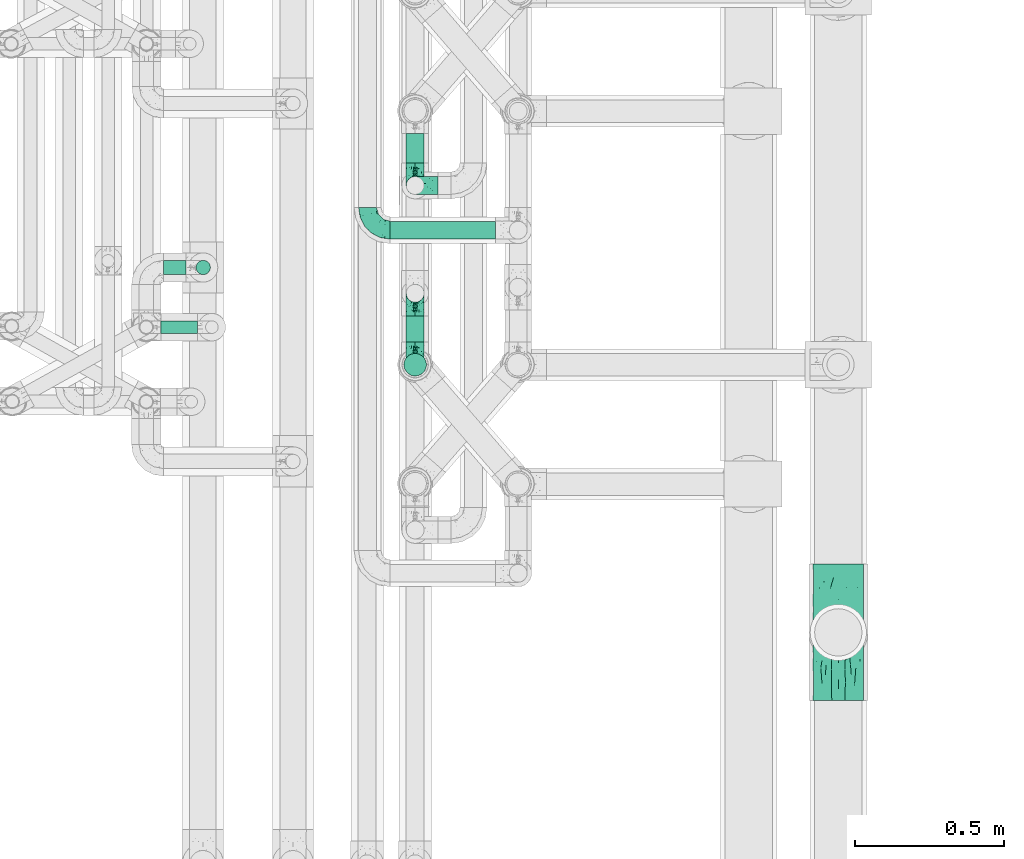
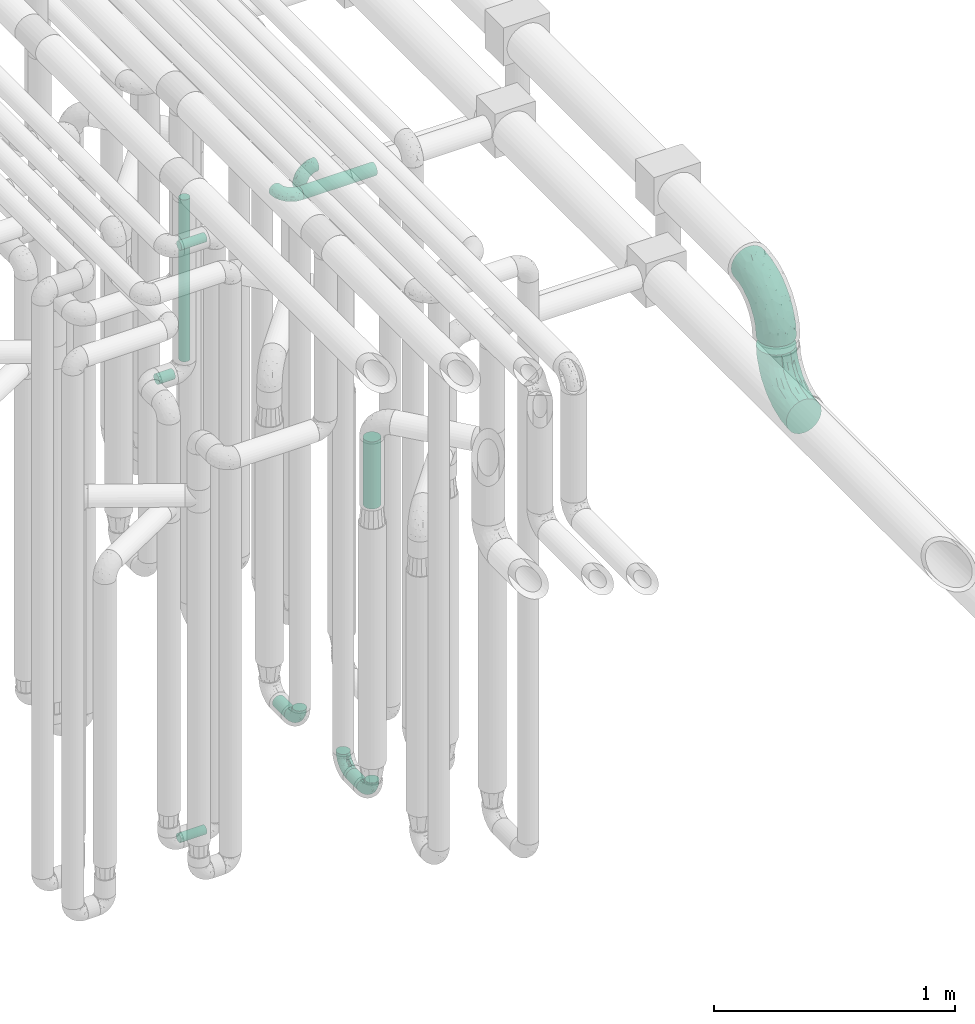
# One storey, part 610 of 827: 8 flow segments, 7 flow fittings.
"""IFC2X3 building model written with IfcOpenShell, lengths in millimetres."""

import ifcopenshell
import ifcopenshell.guid

model = None  # the IFC model being written
_history = None  # IfcOwnerHistory: only IFC2X3 demands one
_inside = {}  # id of a spatial element -> (the spatial element, [elements in it])
_under = {}  # id of a project, library or spatial element -> (it, [spatial elements below it])
_declared = {}  # id of a project -> (the project, [libraries it declares])
_typed = {}  # id of a type object -> (the type object, [elements of that type])
_made_of = {}  # id of a material, layer set ... -> (it, [elements and type objects made of it])


def new_model(schema):
    """Start an empty IFC model of exactly this schema.

    Asked for "IFC4X3", IfcOpenShell would pick the latest addendum, in which some entities
    have other attributes; the version numbers below select the first issue.
    IFC2X3 requires an IfcOwnerHistory on every rooted entity: one is made here for all.
    """
    global model, _history
    if schema == "IFC4X3":
        model = ifcopenshell.file(schema_version=(4, 3, 0, 0))
    else:
        model = ifcopenshell.file(schema=schema)
    _inside.clear()
    _under.clear()
    _declared.clear()
    _typed.clear()
    _made_of.clear()
    _history = None
    if model.schema == "IFC2X3":
        org = make("IfcOrganization", Name="unknown")
        user = make(
            "IfcPersonAndOrganization",
            ThePerson=make("IfcPerson", FamilyName="unknown"),
            TheOrganization=org,
        )
        app = make(
            "IfcApplication",
            ApplicationDeveloper=org,
            Version="unknown",
            ApplicationFullName="unknown",
            ApplicationIdentifier="unknown",
        )
        _history = make(
            "IfcOwnerHistory",
            OwningUser=user,
            OwningApplication=app,
            ChangeAction="ADDED",
            CreationDate=0,
        )
    return model


def make(cls, **values):
    """One entity of the class cls with the attributes given. An attribute that is None is left unset."""
    return model.create_entity(
        cls, **{name: value for name, value in values.items() if value is not None}
    )


def entity(cls, *values):
    """Any entity or typed value of the class cls, its attributes in the order of the schema. None: left unset."""
    e = model.create_entity(cls)
    for i, value in enumerate(values):
        if value is not None:
            e[i] = value
    return e


def rooted(cls, **values):
    """An entity with a GlobalId (a new one), such as an element, a storey or a relation."""
    return make(cls, GlobalId=ifcopenshell.guid.new(), OwnerHistory=_history, **values)


def si_unit(unit_type, name, prefix=None):
    """IfcSIUnit, for example si_unit("LENGTHUNIT", "METRE", prefix="MILLI")."""
    return make("IfcSIUnit", UnitType=unit_type, Prefix=prefix, Name=name)


def converted_unit(unit_type, name, factor, base, dimensions=None, offset=None):
    """IfcConversionBasedUnit, such as the inch: factor (a typed value) times the base unit."""
    return make(
        "IfcConversionBasedUnit"
        if offset is None
        else "IfcConversionBasedUnitWithOffset",
        ConversionOffset=offset,
        Dimensions=None
        if dimensions is None
        else entity("IfcDimensionalExponents", *dimensions),
        UnitType=unit_type,
        Name=name,
        ConversionFactor=make(
            "IfcMeasureWithUnit", ValueComponent=factor, UnitComponent=base
        ),
    )


def derived_unit(unit_type, elements):
    """IfcDerivedUnit: a product of units, each with its exponent."""
    return make(
        "IfcDerivedUnit",
        Elements=[
            make("IfcDerivedUnitElement", Unit=unit, Exponent=power)
            for unit, power in elements
        ],
        UnitType=unit_type,
    )


def assignment(units):
    """IfcUnitAssignment: the units of a project."""
    return None if units is None else make("IfcUnitAssignment", Units=units)


def point(xyz):
    """IfcCartesianPoint."""
    return None if xyz is None else make("IfcCartesianPoint", Coordinates=xyz)


def direction(xyz):
    """IfcDirection."""
    return None if xyz is None else make("IfcDirection", DirectionRatios=xyz)


def frame(location, z_axis=None, x_axis=None):
    """IfcAxis2Placement3D, a coordinate frame: its origin and axes. An axis left out is left unset."""
    return make(
        "IfcAxis2Placement3D",
        Location=point(location),
        Axis=direction(z_axis),
        RefDirection=direction(x_axis),
    )


def frame_2d(location, x_axis=None):
    """IfcAxis2Placement2D, a coordinate frame in the plane: its origin and x axis."""
    return make(
        "IfcAxis2Placement2D", Location=point(location), RefDirection=direction(x_axis)
    )


def origin():
    """The frame at (0, 0, 0) with its axes left unset."""
    return frame((0.0, 0.0, 0.0))


def origin_2d_with_axis():
    """The frame at (0, 0) in the plane with the x axis (1, 0) written out."""
    return frame_2d((0.0, 0.0), x_axis=(1.0, 0.0))


def place(relative_to, where):
    """IfcLocalPlacement: puts the frame where relative to a parent placement (None: the world)."""
    return make(
        "IfcLocalPlacement", PlacementRelTo=relative_to, RelativePlacement=where
    )


def context(
    kind, dimensions, precision=None, world=None, true_north=None, identifier=None
):
    """IfcGeometricRepresentationContext, for example the 3D "Model" context."""
    return make(
        "IfcGeometricRepresentationContext",
        ContextIdentifier=identifier,
        ContextType=kind,
        CoordinateSpaceDimension=dimensions,
        Precision=precision,
        WorldCoordinateSystem=world,
        TrueNorth=true_north,
    )


def subcontext(parent, identifier, kind, view, scale=None):
    """IfcGeometricRepresentationSubContext, for example "Body" below "Model"."""
    return make(
        "IfcGeometricRepresentationSubContext",
        ContextIdentifier=identifier,
        ContextType=kind,
        ParentContext=parent,
        TargetScale=scale,
        TargetView=view,
    )


def project(units=None, contexts=None):
    """IfcProject with its units and contexts."""
    return rooted(
        "IfcProject",
        Name="project",
        RepresentationContexts=contexts,
        UnitsInContext=assignment(units),
    )


def spatial(cls, under=None, at=None, **own):
    """A site, building, storey or space (cls), placed at a placement, below another one or the project."""
    s = rooted(cls, ObjectPlacement=at, **own)
    if under is not None:
        _under.setdefault(under.id(), (under, []))[1].append(s)
    return s


def profile(cls, at=None, kind="AREA", **sizes):
    """A parametric profile (cls). Its sizes go by their IFC names, for example OverallWidth=200.0."""
    return make(cls, ProfileType=kind, Position=at, **sizes)


def circle(**sizes):
    """IfcCircleProfileDef."""
    return profile("IfcCircleProfileDef", **sizes)


def extrude(swept, where, along, depth):
    """IfcExtrudedAreaSolid: the profile swept, set in the frame where, extruded along a direction by depth."""
    return make(
        "IfcExtrudedAreaSolid",
        SweptArea=swept,
        Position=where,
        ExtrudedDirection=direction(along),
        Depth=depth,
    )


def faces_of(points, faces, orient=None, outer=None):
    """IfcFace entities. A face is a list of loops; a loop is a list of indices into points, from 0.

    orient and outer hold one flag for each loop. By default every Orientation is true, the
    first loop of a face is its IfcFaceOuterBound and the others are IfcFaceBound.
    """
    made = []
    for i, loops in enumerate(faces):
        bounds = []
        for j, loop in enumerate(loops):
            is_outer = j == 0 if outer is None else outer[i][j]
            bounds.append(
                make(
                    "IfcFaceOuterBound" if is_outer else "IfcFaceBound",
                    Bound=make("IfcPolyLoop", Polygon=[points[k] for k in loop]),
                    Orientation=True if orient is None else orient[i][j],
                )
            )
        made.append(make("IfcFace", Bounds=bounds))
    return made


def faceted_brep(points, faces, orient=None, outer=None, voids=None):
    """IfcFacetedBrep: a solid bounded by flat faces; with voids (closed shells), ...WithVoids."""
    shared = [point(p) for p in points]
    hull = make("IfcClosedShell", CfsFaces=faces_of(shared, faces, orient, outer))
    if voids is None:
        return make("IfcFacetedBrep", Outer=hull)
    return make(
        "IfcFacetedBrepWithVoids",
        Outer=hull,
        Voids=[
            make(cls, CfsFaces=faces_of(shared, fs, o, b)) for cls, fs, o, b in voids
        ],
    )


def shape(context_of_items, identifier, shape_type, items):
    """IfcShapeRepresentation: the items that make up one representation, for example the "Body"."""
    return make(
        "IfcShapeRepresentation",
        ContextOfItems=context_of_items,
        RepresentationIdentifier=identifier,
        RepresentationType=shape_type,
        Items=items,
    )


def source(mapping_origin, context_of_items, identifier, shape_type, items):
    """IfcRepresentationMap: a shape defined once, which mapped items show again and again."""
    return make(
        "IfcRepresentationMap",
        MappingOrigin=mapping_origin,
        MappedRepresentation=shape(context_of_items, identifier, shape_type, items),
    )


def transform(
    local_origin,
    x_axis=None,
    y_axis=None,
    z_axis=None,
    scale=None,
    scale2=None,
    scale3=None,
    uniform=True,
):
    """IfcCartesianTransformationOperator3D, or its non-uniform kind. x_axis, y_axis, z_axis: its Axis1, 2, 3."""
    if uniform:
        return make(
            "IfcCartesianTransformationOperator3D",
            Axis1=direction(x_axis),
            Axis2=direction(y_axis),
            LocalOrigin=point(local_origin),
            Scale=scale,
            Axis3=direction(z_axis),
        )
    return make(
        "IfcCartesianTransformationOperator3DnonUniform",
        Axis1=direction(x_axis),
        Axis2=direction(y_axis),
        LocalOrigin=point(local_origin),
        Scale=scale,
        Axis3=direction(z_axis),
        Scale2=scale2,
        Scale3=scale3,
    )


def mapped(mapping_source, mapping_target):
    """IfcMappedItem: shows the shape of a source again, moved by a transform."""
    return make(
        "IfcMappedItem", MappingSource=mapping_source, MappingTarget=mapping_target
    )


def material(Name=None, Category=None):
    """IfcMaterial."""
    return make("IfcMaterial", Name=Name, Category=Category)


def made_of(thing, what):
    """Note that an element or type object is made of a material, layer set ...; save() writes the relation."""
    if what is not None:
        _made_of.setdefault(what.id(), (what, []))[1].append(thing)
    return thing


def type_object(cls, material=None, **own):
    """A type object (cls), such as IfcWallType, which elements share."""
    return made_of(rooted(cls, **own), material)


def type_shapes(of_type, sources):
    """Give a type object the sources (RepresentationMaps) that its elements show as mapped items."""
    of_type.RepresentationMaps = sources


def element(
    cls,
    number,
    at=None,
    inside=None,
    cuts=None,
    type_object=None,
    material=None,
    context=None,
    identifier="Body",
    shape_type=None,
    held_by="IfcProductDefinitionShape",
    body=None,
    shapes=None,
    **own,
):
    """One element of the class cls, such as IfcWall. Its Tag is "e" and its number.

    at: its placement. inside: the storey or other place that contains it. cuts: it is an
    opening in that element (IfcRelVoidsElement). A single representation is given by context,
    identifier, shape_type and body (its items); several are given by shapes. held_by: the class
    of the entity that holds the representations. save() writes the other relations.
    """
    e = rooted(cls, Tag="e%d" % number, ObjectPlacement=at, **own)
    if body is not None:
        shapes = [shape(context, identifier, shape_type, body)]
    if shapes is not None:
        e.Representation = make(held_by, Representations=shapes)
    if inside is not None:
        _inside.setdefault(inside.id(), (inside, []))[1].append(e)
    if cuts is not None:
        rooted(
            "IfcRelVoidsElement", RelatingBuildingElement=cuts, RelatedOpeningElement=e
        )
    if type_object is not None:
        _typed.setdefault(type_object.id(), (type_object, []))[1].append(e)
    return made_of(e, material)


def aggregate(whole, parts):
    """IfcRelAggregates: a whole, such as a stair, and the parts it consists of."""
    return rooted("IfcRelAggregates", RelatingObject=whole, RelatedObjects=parts)


def save(model, path):
    """Write the relations noted so far, then the file.

    IfcRelAggregates (storeys below a building ...), IfcRelContainedInSpatialStructure (elements
    in a storey), IfcRelDefinesByType, IfcRelAssociatesMaterial and IfcRelDeclares: one each for
    every whole, place, type object, material and project.
    """
    for whole, parts in _under.values():
        aggregate(whole, parts)
    for where, things in _inside.values():
        rooted(
            "IfcRelContainedInSpatialStructure",
            RelatedElements=things,
            RelatingStructure=where,
        )
    for kind, things in _typed.values():
        rooted("IfcRelDefinesByType", RelatedObjects=things, RelatingType=kind)
    for what, things in _made_of.values():
        rooted("IfcRelAssociatesMaterial", RelatedObjects=things, RelatingMaterial=what)
    for by, libraries in _declared.values():
        rooted("IfcRelDeclares", RelatingContext=by, RelatedDefinitions=libraries)
    model.write(path)


model = new_model("IFC2X3")

# Units and contexts
model_context = context("Model", 3, precision=0.01, world=origin(), true_north=direction((6.12303176911189e-17, 1.0)))
body_context = subcontext(model_context, "Body", "Model", "MODEL_VIEW")
ifc_project = project(units=[si_unit("LENGTHUNIT", "METRE", prefix="MILLI"), si_unit("AREAUNIT", "SQUARE_METRE"), si_unit("VOLUMEUNIT", "CUBIC_METRE"), converted_unit("PLANEANGLEUNIT", "DEGREE", entity("IfcRatioMeasure", 0.0174532925199433), si_unit("PLANEANGLEUNIT", "RADIAN"), dimensions=[0, 0, 0, 0, 0, 0, 0]), si_unit("MASSUNIT", "GRAM", prefix="KILO"), derived_unit("MASSDENSITYUNIT", [(si_unit("MASSUNIT", "GRAM", prefix="KILO"), 1), (si_unit("LENGTHUNIT", "METRE"), -3)]), derived_unit("MOMENTOFINERTIAUNIT", [(si_unit("LENGTHUNIT", "METRE"), 4)]), si_unit("TIMEUNIT", "SECOND"), si_unit("FREQUENCYUNIT", "HERTZ"), si_unit("THERMODYNAMICTEMPERATUREUNIT", "DEGREE_CELSIUS"), derived_unit("THERMALTRANSMITTANCEUNIT", [(si_unit("MASSUNIT", "GRAM", prefix="KILO"), 1), (si_unit("THERMODYNAMICTEMPERATUREUNIT", "KELVIN"), -1), (si_unit("TIMEUNIT", "SECOND"), -3)]), derived_unit("VOLUMETRICFLOWRATEUNIT", [(si_unit("LENGTHUNIT", "METRE"), 3), (si_unit("TIMEUNIT", "SECOND"), -1)]), derived_unit("MASSFLOWRATEUNIT", [(si_unit("MASSUNIT", "GRAM", prefix="KILO"), 1), (si_unit("TIMEUNIT", "SECOND"), -1)]), derived_unit("ROTATIONALFREQUENCYUNIT", [(si_unit("TIMEUNIT", "SECOND"), -1)]), si_unit("ELECTRICCURRENTUNIT", "AMPERE"), si_unit("ELECTRICVOLTAGEUNIT", "VOLT"), si_unit("POWERUNIT", "WATT"), si_unit("FORCEUNIT", "NEWTON", prefix="KILO"), si_unit("ILLUMINANCEUNIT", "LUX"), si_unit("LUMINOUSFLUXUNIT", "LUMEN"), si_unit("LUMINOUSINTENSITYUNIT", "CANDELA"), derived_unit("USERDEFINED", [(si_unit("MASSUNIT", "GRAM", prefix="KILO"), -1), (si_unit("LENGTHUNIT", "METRE"), -2), (si_unit("TIMEUNIT", "SECOND"), 3), (si_unit("LUMINOUSFLUXUNIT", "LUMEN"), 1)]), derived_unit("LINEARVELOCITYUNIT", [(si_unit("LENGTHUNIT", "METRE"), 1), (si_unit("TIMEUNIT", "SECOND"), -1)]), si_unit("PRESSUREUNIT", "PASCAL"), derived_unit("USERDEFINED", [(si_unit("LENGTHUNIT", "METRE"), -2), (si_unit("MASSUNIT", "GRAM", prefix="KILO"), 1), (si_unit("TIMEUNIT", "SECOND"), -2)]), derived_unit("LINEARFORCEUNIT", [(si_unit("MASSUNIT", "GRAM", prefix="KILO"), 1), (si_unit("LENGTHUNIT", "METRE"), 1), (si_unit("TIMEUNIT", "SECOND"), -2), (si_unit("LENGTHUNIT", "METRE"), -1)]), derived_unit("PLANARFORCEUNIT", [(si_unit("MASSUNIT", "GRAM", prefix="KILO"), 1), (si_unit("LENGTHUNIT", "METRE"), 1), (si_unit("TIMEUNIT", "SECOND"), -2), (si_unit("LENGTHUNIT", "METRE"), -2)])], contexts=[model_context])

# Site, building, storey
site_placement = place(None, origin())
site = spatial("IfcSite", under=ifc_project, at=site_placement, CompositionType="ELEMENT")
building_placement = place(site_placement, origin())
building = spatial("IfcBuilding", under=site, at=building_placement, CompositionType="ELEMENT")
storey_placement = place(building_placement, frame((0.0, 0.0, 28200.0)))
storey = spatial("IfcBuildingStorey", under=building, at=storey_placement, Name="08", CompositionType="ELEMENT", Elevation=28200.0)

# Flow segments
pipe_segment_type = type_object("IfcPipeSegmentType", PredefinedType="NOTDEFINED")
flow_segment_1_placement = place(storey_placement, frame((36598.05, 11157.17, 368.4)))
element("IfcFlowSegment", 1, at=flow_segment_1_placement, inside=storey, type_object=pipe_segment_type, context=body_context, shape_type="SweptSolid", body=[
    extrude(circle(Radius=30.0, at=origin_2d_with_axis()), frame((31.6, 0.0, 31.6), z_axis=(0.0, 1.0, 0.0), x_axis=(1.0, 0.0, 0.0)), (0.0, 0.0, 1.0), 98.4177180789936),
])
flow_segment_2_placement = place(storey_placement, frame((36546.03, 10899.58, 3168.4)))
element("IfcFlowSegment", 2, at=flow_segment_2_placement, inside=storey, type_object=pipe_segment_type, context=body_context, shape_type="SweptSolid", body=[
    extrude(circle(Radius=30.0, at=origin_2d_with_axis()), frame((0.0, 31.6, 31.6), z_axis=(1.0, 0.0, 0.0), x_axis=(0.0, 1.0, 0.0)), (0.0, 0.0, 1.0), 352.999982000065),
])
flow_segment_3_placement = place(storey_placement, frame((36598.05, 10556.2, 368.4)))
element("IfcFlowSegment", 3, at=flow_segment_3_placement, inside=storey, type_object=pipe_segment_type, context=body_context, shape_type="SweptSolid", body=[
    extrude(circle(Radius=30.0, at=origin_2d_with_axis()), frame((31.6, 0.0, 31.6), z_axis=(0.0, 1.0, 0.0), x_axis=(-1.0, 0.0, 0.0)), (0.0, 0.0, 1.0), 87.5194852591066),
])
flow_segment_4_placement = place(storey_placement, frame((36590.3, 10440.86, 1870.0)))
element("IfcFlowSegment", 4, at=flow_segment_4_placement, inside=storey, type_object=pipe_segment_type, context=body_context, shape_type="SweptSolid", body=[
    extrude(circle(Radius=37.75, at=origin_2d_with_axis()), frame((39.35, 39.35, 0.0)), (0.0, 0.0, 1.0), 340.000000000014),
])
flow_segment_5_placement = place(storey_placement, frame((35776.05, 10583.46, 377.25)))
element("IfcFlowSegment", 5, at=flow_segment_5_placement, inside=storey, type_object=pipe_segment_type, context=body_context, shape_type="SweptSolid", body=[
    extrude(circle(Radius=21.15, at=origin_2d_with_axis()), frame((0.0, 22.75, 22.75), z_axis=(1.0, 0.0, 0.0), x_axis=(0.0, 1.0, 0.0)), (0.0, 0.0, 1.0), 124.000000000006),
])
flow_segment_6_placement = place(storey_placement, frame((35785.05, 10780.61, 2574.4)))
element("IfcFlowSegment", 6, at=flow_segment_6_placement, inside=storey, type_object=pipe_segment_type, context=body_context, shape_type="SweptSolid", body=[
    extrude(circle(Radius=24.0, at=origin_2d_with_axis()), frame((0.0, 25.6, 25.6), z_axis=(1.0, -8.65020701261313e-08, 0.0), x_axis=(-8.65020701261313e-08, -1.0, 0.0)), (0.0, 0.0, 1.0), 76.9274934935988),
])
flow_segment_7_placement = place(storey_placement, frame((35893.38, 10780.61, 2657.0)))
element("IfcFlowSegment", 7, at=flow_segment_7_placement, inside=storey, type_object=pipe_segment_type, context=body_context, shape_type="SweptSolid", body=[
    extrude(circle(Radius=24.0, at=origin_2d_with_axis()), frame((25.6, 25.6, 0.0)), (0.0, 0.0, 1.0), 820.000867851719),
])
flow_segment_8_placement = place(storey_placement, frame((35778.03, 10583.46, 3377.25)))
element("IfcFlowSegment", 8, at=flow_segment_8_placement, inside=storey, type_object=pipe_segment_type, context=body_context, shape_type="SweptSolid", body=[
    extrude(circle(Radius=21.15, at=origin_2d_with_axis()), frame((0.0, 22.75, 22.75), z_axis=(1.0, 0.0, 0.0), x_axis=(0.0, 1.0, 0.0)), (0.0, 0.0, 1.0), 122.01386037804),
])

# Flow fittings
ifc_material = material()
pipe_fitting_type_1 = type_object("IfcPipeFittingType", Name="ADSK_1", PredefinedType="NOTDEFINED", material=ifc_material)
shared_shape_1 = source(origin(), body_context, "Body", "Brep", [
    faceted_brep([(-76.0, 15.07, -26.11), (-76.0, 7.8, -29.12), (-76.0, 0.0, -30.15), (-76.0, -7.8, -29.12), (-76.0, -15.08, -26.11), (-76.0, -21.32, -21.32), (-76.0, -26.11, -15.08), (-76.0, -29.12, -7.8), (-76.0, -30.15, 0.0), (-76.0, -29.12, 7.8), (-76.0, -26.11, 15.07), (-76.0, -21.32, 21.32), (-76.0, -15.08, 26.11), (-76.0, -7.8, 29.12), (-76.0, 0.0, 30.15), (-76.0, 7.8, 29.12), (-76.0, 15.07, 26.11), (-76.0, 21.32, 21.32), (-76.0, 26.11, 15.07), (-76.0, 29.12, 7.8), (-76.0, 30.15, 0.0), (-76.0, 29.12, -7.8), (-76.0, 26.11, -15.08), (-76.0, 21.32, -21.32), (0.0, 76.0, -30.15), (-7.8, 76.0, -29.12), (-15.07, 76.0, -26.11), (-21.32, 76.0, -21.32), (-26.11, 76.0, -15.08), (-29.12, 76.0, -7.8), (-30.15, 76.0, 0.0), (-29.12, 76.0, 7.8), (-26.11, 76.0, 15.07), (-21.32, 76.0, 21.32), (-15.07, 76.0, 26.11), (-7.8, 76.0, 29.12), (0.0, 76.0, 30.15), (7.8, 76.0, 29.12), (15.08, 76.0, 26.11), (21.32, 76.0, 21.32), (26.11, 76.0, 15.07), (29.12, 76.0, 7.8), (30.15, 76.0, 0.0), (29.12, 76.0, -7.8), (26.11, 76.0, -15.08), (21.32, 76.0, -21.32), (15.08, 76.0, -26.11), (7.8, 76.0, -29.12), (10.79, 31.43, 21.07), (4.32, 31.7, 25.72), (1.65, 15.19, 19.92), (-61.17, -27.8, 0.0), (-51.1, -25.49, 9.84), (-56.14, -10.61, 27.27), (-31.7, -4.32, 25.72), (-39.75, 1.72, 29.41), (-43.2, -24.95, 0.0), (-1.86, 1.86, 0.0), (4.49, 7.65, 5.78), (-7.82, -4.61, 5.83), (-56.21, -22.79, 17.21), (-58.98, -3.38, 29.7), (-53.96, 5.6, 30.07), (-10.86, 10.86, 25.48), (-17.2, -2.6, 20.44), (-49.15, -16.01, 22.7), (-22.18, -14.24, 7.99), (-28.4, -17.42, 0.0), (-13.61, -9.88, 0.0), (-39.0, 23.48, 27.76), (-58.76, 12.54, 28.36), (-41.61, 15.41, 29.48), (16.01, 49.15, 22.7), (-58.55, 25.93, 19.53), (-51.53, 33.5, 13.51), (-64.92, 28.76, 12.4), (-7.48, 23.14, 28.25), (-1.72, 39.75, 29.41), (-12.04, 27.88, 29.88), (-63.91, 18.81, 24.52), (-11.63, 65.16, 28.18), (-4.97, 57.02, 30.05), (9.88, 13.61, 0.0), (-62.5, 31.74, 5.02), (-45.17, 30.98, 21.2), (-21.78, 9.76, 28.58), (10.61, 56.14, 27.27), (-32.09, 54.42, 13.26), (22.79, 56.21, 17.21), (15.38, 31.17, 15.63), (25.49, 51.1, 9.84), (21.84, 36.35, 5.92), (24.95, 43.2, 0.0), (3.38, 58.98, 29.7), (-31.17, -15.38, 15.63), (-39.39, 41.78, 15.45), (-34.56, 41.13, 20.79), (-39.81, -23.25, 5.49), (27.8, 61.17, 0.0), (-31.74, 62.5, 5.02), (-53.07, 36.29, 0.0), (-42.95, 42.95, 7.29), (-36.29, 53.07, 0.0), (-19.83, 58.51, 24.79), (-25.48, 60.2, 19.41), (-14.53, 50.96, 28.57), (-13.31, 37.09, 30.07), (-26.16, 40.06, 26.4), (-32.43, -10.35, 21.9), (17.42, 28.4, 0.0), (14.24, 22.18, 7.99), (-38.67, 9.72, 30.15), (-24.66, 17.36, 30.09), (-37.08, 31.49, 24.99), (-49.27, 22.83, 25.24), (-20.8, 38.81, 28.63), (-27.58, 27.58, 29.2), (-36.07, -20.23, 10.71), (-15.19, -6.16, 14.9), (6.6, 15.4, 14.49), (-2.51, 2.51, 11.35), (-65.16, 11.63, -28.18), (-49.15, -16.01, -22.7), (-57.02, 4.97, -30.05), (-25.93, 58.55, -19.53), (-33.5, 51.53, -13.51), (-28.76, 64.92, -12.4), (-60.2, 25.48, -19.41), (-58.51, 19.83, -24.79), (4.61, 7.82, -5.83), (-7.65, -4.49, -5.78), (-2.51, 2.51, -11.35), (-62.5, 31.74, -5.02), (-50.96, 14.53, -28.57), (-37.09, 13.31, -30.07), (-42.95, 42.95, -7.29), (25.49, 51.1, -9.84), (22.79, 56.21, -17.21), (-40.06, 26.16, -26.4), (3.38, 58.98, -29.7), (-5.6, 53.96, -30.07), (-27.88, 12.04, -29.88), (-9.76, 21.78, -28.58), (-23.14, 7.48, -28.25), (-51.1, -25.49, -9.84), (15.38, 31.17, -15.63), (16.01, 49.15, -22.7), (-23.48, 39.0, -27.76), (-12.54, 58.76, -28.36), (-15.41, 41.61, -29.48), (-56.21, -22.79, -17.21), (-9.72, 38.67, -30.15), (-17.36, 24.66, -30.09), (-22.18, -14.24, -7.99), (-41.13, 34.56, -20.79), (-31.74, 62.5, -5.02), (-58.98, -3.38, -29.7), (-31.17, -15.38, -15.63), (-56.14, -10.61, -27.27), (14.24, 22.18, -7.99), (23.25, 39.81, -5.49), (-31.49, 37.08, -24.99), (-15.19, -6.16, -14.9), (1.65, 15.19, -19.92), (-18.81, 63.91, -24.52), (-32.59, -11.62, -20.84), (-31.7, -4.32, -25.72), (-17.2, -2.6, -20.44), (-39.75, 1.72, -29.41), (-54.42, 32.09, -13.26), (-30.98, 45.17, -21.2), (10.61, 56.14, -27.27), (10.23, 31.31, -21.52), (4.32, 31.7, -25.72), (-41.78, 39.39, -15.45), (-1.72, 39.75, -29.41), (-36.35, -21.84, -5.92), (-22.83, 49.27, -25.24), (-38.81, 20.8, -28.63), (-27.58, 27.58, -29.2), (-10.86, 10.86, -25.48), (20.23, 36.07, -10.71), (6.6, 15.4, -14.49)], [[[0, 1, 2, 3, 4, 5, 6, 7, 8, 9, 10, 11, 12, 13, 14, 15, 16, 17, 18, 19, 20, 21, 22, 23]], [[24, 25, 26, 27, 28, 29, 30, 31, 32, 33, 34, 35, 36, 37, 38, 39, 40, 41, 42, 43, 44, 45, 46, 47]], [[48, 49, 50]], [[51, 52, 9]], [[53, 54, 55]], [[9, 52, 10]], [[56, 52, 51]], [[57, 58, 59]], [[11, 10, 60]], [[14, 61, 62]], [[63, 54, 64]], [[65, 12, 11]], [[65, 53, 12]], [[66, 67, 68]], [[69, 70, 71]], [[72, 39, 38]], [[73, 74, 75]], [[15, 70, 16]], [[76, 77, 78]], [[16, 79, 17]], [[13, 61, 14]], [[35, 80, 81]], [[14, 62, 15]], [[17, 73, 18]], [[57, 82, 58]], [[20, 19, 83]], [[75, 19, 18]], [[70, 15, 62]], [[73, 84, 74]], [[78, 85, 76]], [[38, 86, 72]], [[32, 31, 87]], [[88, 89, 90]], [[91, 92, 90]], [[72, 86, 49]], [[36, 93, 37]], [[75, 83, 19]], [[36, 35, 81]], [[60, 94, 65]], [[40, 90, 41]], [[95, 96, 87]], [[88, 90, 40]], [[66, 97, 67]], [[90, 98, 41]], [[40, 39, 88]], [[99, 31, 30]], [[20, 83, 100]], [[101, 102, 100]], [[52, 60, 10]], [[102, 99, 30]], [[96, 103, 104]], [[83, 101, 100]], [[12, 53, 13]], [[104, 103, 33]], [[105, 106, 81]], [[107, 105, 103]], [[64, 54, 108]], [[80, 103, 105]], [[80, 35, 34]], [[34, 33, 103]], [[86, 38, 37]], [[109, 110, 82]], [[71, 111, 112]], [[69, 107, 113]], [[79, 73, 17]], [[114, 113, 84]], [[33, 32, 104]], [[115, 107, 116]], [[105, 115, 106]], [[93, 81, 77]], [[54, 53, 65]], [[61, 53, 55]], [[108, 94, 64]], [[54, 63, 85]], [[93, 86, 37]], [[77, 76, 49]], [[77, 49, 86]], [[49, 63, 50]], [[60, 52, 117]], [[65, 11, 60]], [[39, 72, 88]], [[89, 88, 72]], [[71, 70, 62]], [[79, 70, 114]], [[103, 96, 107]], [[69, 113, 114]], [[112, 106, 116]], [[77, 81, 106]], [[112, 116, 71]], [[112, 55, 85]], [[64, 50, 63]], [[57, 59, 68]], [[32, 87, 104]], [[96, 104, 87]], [[94, 118, 64]], [[50, 119, 89]], [[50, 64, 118]], [[50, 89, 48]], [[81, 93, 36]], [[86, 93, 77]], [[53, 61, 13]], [[62, 61, 55]], [[71, 62, 111]], [[69, 71, 116]], [[95, 101, 74]], [[99, 101, 87]], [[118, 66, 59]], [[117, 97, 66]], [[117, 66, 94]], [[91, 89, 110]], [[91, 110, 109]], [[110, 89, 119]], [[9, 8, 51]], [[98, 90, 92]], [[98, 42, 41]], [[101, 83, 74]], [[101, 99, 102]], [[87, 31, 99]], [[62, 55, 111]], [[55, 112, 111]], [[107, 69, 116]], [[70, 69, 114]], [[107, 96, 113]], [[84, 113, 96]], [[84, 96, 95]], [[114, 84, 73]], [[70, 79, 16]], [[73, 79, 114]], [[54, 85, 55]], [[76, 85, 63]], [[49, 76, 63]], [[77, 106, 78]], [[106, 112, 78]], [[85, 78, 112]], [[73, 75, 18]], [[83, 75, 74]], [[103, 80, 34]], [[81, 80, 105]], [[101, 95, 87]], [[84, 95, 74]], [[106, 115, 116]], [[105, 107, 115]], [[120, 59, 58]], [[82, 110, 58]], [[119, 58, 110]], [[118, 59, 120]], [[66, 68, 59]], [[54, 65, 108]], [[94, 108, 65]], [[66, 118, 94]], [[50, 118, 120]], [[50, 120, 119]], [[119, 120, 58]], [[89, 72, 48]], [[49, 48, 72]], [[60, 117, 94]], [[117, 52, 97]], [[52, 56, 97]], [[67, 97, 56]], [[92, 91, 109]], [[89, 91, 90]], [[121, 1, 0]], [[122, 5, 4]], [[2, 1, 123]], [[124, 125, 126]], [[127, 128, 23]], [[129, 130, 131]], [[100, 132, 20]], [[133, 134, 123]], [[135, 100, 102]], [[136, 137, 44]], [[133, 128, 138]], [[24, 139, 140]], [[141, 142, 143]], [[121, 128, 133]], [[6, 144, 7]], [[137, 145, 146]], [[144, 51, 7]], [[147, 148, 149]], [[144, 6, 150]], [[149, 151, 152]], [[153, 68, 67]], [[154, 128, 127]], [[30, 155, 102]], [[43, 42, 98]], [[156, 3, 2]], [[157, 144, 150]], [[158, 4, 3]], [[24, 140, 25]], [[155, 135, 102]], [[159, 160, 109]], [[30, 29, 155]], [[147, 138, 161]], [[27, 124, 28]], [[57, 129, 82]], [[162, 163, 131]], [[27, 26, 164]], [[148, 26, 25]], [[165, 166, 167]], [[24, 47, 139]], [[143, 168, 141]], [[22, 21, 169]], [[125, 124, 170]], [[148, 25, 140]], [[46, 146, 171]], [[158, 122, 4]], [[0, 23, 128]], [[1, 121, 123]], [[109, 82, 159]], [[45, 44, 137]], [[146, 46, 45]], [[136, 43, 98]], [[132, 21, 20]], [[136, 98, 92]], [[172, 173, 146]], [[46, 171, 47]], [[43, 136, 44]], [[174, 154, 169]], [[171, 173, 175]], [[6, 5, 150]], [[126, 29, 28]], [[176, 56, 144]], [[122, 158, 166]], [[164, 124, 27]], [[177, 161, 170]], [[23, 22, 127]], [[178, 138, 179]], [[133, 178, 134]], [[156, 123, 168]], [[156, 158, 3]], [[168, 143, 166]], [[168, 166, 158]], [[166, 180, 167]], [[173, 171, 146]], [[139, 171, 175]], [[172, 145, 163]], [[173, 180, 142]], [[5, 122, 150]], [[157, 150, 122]], [[137, 136, 181]], [[146, 45, 137]], [[149, 148, 140]], [[164, 148, 177]], [[128, 154, 138]], [[147, 161, 177]], [[152, 134, 179]], [[168, 123, 134]], [[152, 179, 149]], [[152, 175, 142]], [[57, 130, 129]], [[157, 165, 167]], [[22, 169, 127]], [[154, 127, 169]], [[163, 167, 180]], [[162, 157, 167]], [[173, 163, 180]], [[182, 163, 145]], [[123, 156, 2]], [[158, 156, 168]], [[171, 139, 47]], [[140, 139, 175]], [[149, 140, 151]], [[147, 149, 179]], [[174, 135, 125]], [[132, 135, 169]], [[176, 157, 153]], [[176, 153, 67]], [[153, 157, 162]], [[182, 159, 129]], [[181, 160, 159]], [[181, 159, 145]], [[51, 144, 56]], [[51, 8, 7]], [[135, 132, 100]], [[169, 21, 132]], [[126, 155, 29]], [[135, 155, 125]], [[140, 175, 151]], [[175, 152, 151]], [[138, 147, 179]], [[148, 147, 177]], [[138, 154, 161]], [[170, 161, 154]], [[170, 154, 174]], [[177, 170, 124]], [[148, 164, 26]], [[124, 164, 177]], [[173, 142, 175]], [[143, 142, 180]], [[166, 143, 180]], [[168, 134, 141]], [[134, 152, 141]], [[142, 141, 152]], [[124, 126, 28]], [[155, 126, 125]], [[128, 121, 0]], [[123, 121, 133]], [[135, 174, 169]], [[170, 174, 125]], [[134, 178, 179]], [[133, 138, 178]], [[130, 153, 162]], [[68, 153, 130]], [[57, 68, 130]], [[182, 129, 131]], [[159, 82, 129]], [[157, 122, 165]], [[166, 165, 122]], [[163, 162, 167]], [[162, 131, 130]], [[145, 172, 146]], [[163, 173, 172]], [[159, 182, 145]], [[131, 163, 182]], [[56, 176, 67]], [[157, 176, 144]], [[137, 181, 145]], [[181, 136, 160]], [[136, 92, 160]], [[109, 160, 92]]]),
])
type_shapes(pipe_fitting_type_1, [shared_shape_1])
for number, where, z_axis, x_axis, name in (
    (9, (36629.64, 11081.17, 400.0), (-1.0, 0.0, 0.0), (0.0, -1.0, 0.0), "ADSK_1"),
    (10, (36629.64, 11081.17, 3200.0), (0.0, 1.0, 0.0), (0.0, 0.0, 1.0), "ADSK_1"),
    (11, (36470.03, 10931.17, 3200.0), (0.0, 0.0, 1.0), (0.0, -1.0, 0.0), "ADSK_1"),
    (12, (36629.64, 10480.2, 400.0), (-1.0, 0.0, 0.0), (0.0, -1.0, 0.0), "ADSK_1"),
    (13, (36629.64, 10719.72, 400.0), (1.0, 0.0, 0.0), (0.0, 1.0, 0.0), "ADSK_1"),
):
    element("IfcFlowFitting", number, at=place(storey_placement, frame(where, z_axis=z_axis, x_axis=x_axis)), inside=storey, type_object=pipe_fitting_type_1, material=ifc_material, Name=name, ObjectType="ADSK_1", context=body_context, shape_type="MappedRepresentation", body=[
        mapped(shared_shape_1, transform((0.0, 0.0, 0.0), scale=1.0)),
    ])
pipe_fitting_type_2 = type_object("IfcPipeFittingType", Name="ADSK_1", PredefinedType="NOTDEFINED", material=ifc_material)
shared_shape_2 = source(origin(), body_context, "Body", "Brep", [
    faceted_brep([(-229.0, 0.0, -84.15), (-229.0, -21.78, -81.28), (-229.0, -42.08, -72.88), (-229.0, -59.5, -59.5), (-229.0, -72.88, -42.08), (-229.0, -81.28, -21.78), (-229.0, -84.15, 0.0), (-229.0, -81.28, 21.78), (-229.0, -72.88, 42.07), (-229.0, -59.5, 59.5), (-229.0, -42.08, 72.88), (-229.0, -21.78, 81.28), (-229.0, 0.0, 84.15), (-229.0, 21.78, 81.28), (-229.0, 42.07, 72.88), (-229.0, 59.5, 59.5), (-229.0, 72.88, 42.07), (-229.0, 81.28, 21.78), (-229.0, 84.15, 0.0), (-229.0, 81.28, -21.78), (-229.0, 72.88, -42.08), (-229.0, 59.5, -59.5), (-229.0, 42.07, -72.88), (-229.0, 21.78, -81.28), (-21.78, 229.0, -81.28), (-42.07, 229.0, -72.88), (-59.5, 229.0, -59.5), (-72.88, 229.0, -42.08), (-81.28, 229.0, -21.78), (-84.15, 229.0, 0.0), (-81.28, 229.0, 21.78), (-72.88, 229.0, 42.07), (-59.5, 229.0, 59.5), (-42.07, 229.0, 72.88), (-21.78, 229.0, 81.28), (0.0, 229.0, 84.15), (21.78, 229.0, 81.28), (42.08, 229.0, 72.88), (59.5, 229.0, 59.5), (72.88, 229.0, 42.07), (81.28, 229.0, 21.78), (84.15, 229.0, 0.0), (81.28, 229.0, -21.78), (72.88, 229.0, -42.08), (59.5, 229.0, -59.5), (42.08, 229.0, -72.88), (21.78, 229.0, -81.28), (0.0, 229.0, -84.15), (-34.61, -10.71, 27.22), (-55.02, -31.37, 0.0), (-7.57, 7.57, 0.0), (-149.72, -43.77, 63.64), (-169.02, -62.85, 48.23), (-97.08, -41.04, 44.31), (43.74, 149.63, 63.64), (-150.89, -69.45, 27.59), (-167.91, -78.13, 0.0), (-169.91, -28.92, 76.25), (-97.55, -9.68, 72.04), (-121.24, 6.78, 82.21), (-96.91, 144.03, 43.65), (-73.63, 174.11, 54.38), (-80.69, 186.02, 38.97), (-86.15, -46.8, 20.56), (-109.16, -60.31, 0.0), (-124.39, 124.47, 22.4), (-103.56, 156.57, 0.0), (-126.58, 126.58, 0.0), (35.5, 108.57, 57.3), (9.66, 97.54, 72.05), (11.96, 68.74, 58.61), (-101.29, 118.78, 58.7), (-131.94, 107.76, 40.63), (-0.74, 32.58, 43.33), (-53.96, -2.75, 57.52), (-51.65, -14.54, 43.1), (-16.57, 163.16, 83.89), (-191.29, 53.06, 68.37), (-177.15, 35.68, 79.05), (-163.16, 16.57, 83.89), (-156.57, 103.56, 0.0), (-167.51, 94.43, 22.63), (-31.77, 69.64, 80.49), (-51.86, 77.64, 84.06), (-75.73, 38.17, 82.66), (-178.42, -8.89, 82.94), (-45.56, 125.13, 82.16), (-29.47, 118.52, 84.14), (-134.93, 93.38, 54.7), (-171.88, 85.3, 39.38), (-174.11, 73.63, 54.38), (-191.51, 89.09, 0.0), (-94.25, 167.16, 23.72), (60.31, 109.16, 0.0), (69.17, 149.76, 27.52), (46.74, 86.31, 21.07), (78.13, 167.91, 0.0), (-35.68, 177.15, 79.05), (-115.39, 29.55, 84.15), (-125.13, 45.56, 82.16), (-99.58, -26.69, 61.37), (62.85, 168.99, 48.23), (40.19, 95.7, 44.56), (28.91, 169.89, 76.25), (8.89, 178.42, 82.94), (-96.46, 98.16, 72.48), (-66.09, 146.26, 70.28), (-89.09, 191.51, 0.0), (12.11, 32.77, 19.46), (31.37, 55.02, 0.0), (-53.06, 191.29, 68.37), (-6.78, 121.24, 82.21), (-142.97, 52.5, 77.56), (-146.26, 66.09, 70.28), (-20.69, 32.03, 61.26), (-35.96, 35.96, 71.73), (-85.04, 13.46, 78.55), (-82.46, 82.46, 81.29), (-52.5, 142.97, 77.56), (-177.15, 35.68, -79.05), (-163.16, 16.57, -83.89), (12.11, 32.77, -19.46), (46.74, 86.31, -21.07), (-121.24, 6.78, -82.21), (-178.42, -8.89, -82.94), (-131.94, 107.76, -40.63), (-174.11, 73.63, -54.38), (-184.82, 81.45, -38.2), (-125.13, 45.56, -82.16), (40.19, 95.7, -44.56), (-167.51, 94.43, -22.63), (-147.87, -68.96, -26.69), (-86.11, -46.82, -20.42), (-124.39, 124.47, -22.4), (-191.29, 53.06, -68.37), (-146.26, 66.09, -70.28), (-96.91, 144.03, -43.65), (-101.29, 118.78, -58.7), (8.89, 178.42, -82.94), (-16.57, 163.16, -83.89), (-66.09, 146.26, -70.28), (-96.46, 98.16, -72.48), (-169.02, -62.85, -48.23), (-29.55, 115.39, -84.15), (-45.56, 125.13, -82.16), (-149.72, -43.77, -63.64), (-133.88, 87.62, -60.39), (-181.01, -78.74, -16.77), (-97.08, -41.04, -44.31), (-52.5, 142.97, -77.56), (-35.68, 177.15, -79.05), (-118.52, 29.47, -84.14), (-34.61, -10.71, -27.22), (-73.63, 174.11, -54.38), (-169.91, -28.92, -76.25), (69.17, 149.76, -27.52), (-100.07, -29.93, -58.74), (-97.55, -9.68, -72.04), (-53.96, -2.75, -57.52), (-94.25, 167.16, -23.72), (-77.64, 51.86, -84.06), (-0.74, 32.58, -43.33), (-53.06, 191.29, -68.37), (-80.69, 186.02, -38.97), (-69.64, 31.77, -80.49), (-38.17, 75.73, -82.66), (43.74, 149.63, -63.64), (28.91, 169.89, -76.25), (9.66, 97.54, -72.05), (-6.78, 121.24, -82.21), (11.96, 68.74, -58.61), (62.85, 168.99, -48.23), (27.5, 107.32, -63.78), (-13.47, 85.05, -78.55), (-35.96, 35.96, -71.73), (-82.46, 82.46, -81.29), (-142.97, 52.5, -77.56), (-37.91, -3.62, -43.48), (-16.75, 29.32, -56.44)], [[[0, 1, 2, 3, 4, 5, 6, 7, 8, 9, 10, 11, 12, 13, 14, 15, 16, 17, 18, 19, 20, 21, 22, 23]], [[24, 25, 26, 27, 28, 29, 30, 31, 32, 33, 34, 35, 36, 37, 38, 39, 40, 41, 42, 43, 44, 45, 46, 47]], [[48, 49, 50]], [[51, 52, 53]], [[54, 38, 37]], [[55, 8, 7]], [[7, 6, 56]], [[57, 58, 59]], [[52, 8, 55]], [[60, 61, 62]], [[49, 48, 63]], [[49, 63, 64]], [[10, 9, 51]], [[65, 66, 67]], [[51, 57, 10]], [[68, 69, 70]], [[71, 60, 72]], [[73, 74, 75]], [[76, 35, 34]], [[15, 14, 77]], [[78, 13, 79]], [[65, 80, 81]], [[12, 79, 13]], [[82, 83, 84]], [[12, 11, 85]], [[86, 87, 76]], [[88, 89, 90]], [[91, 81, 80]], [[30, 92, 62]], [[91, 18, 17]], [[72, 60, 65]], [[12, 85, 79]], [[15, 77, 90]], [[89, 17, 16]], [[13, 78, 14]], [[91, 17, 81]], [[53, 55, 63]], [[61, 60, 71]], [[93, 94, 95]], [[86, 83, 87]], [[40, 39, 94]], [[93, 96, 94]], [[34, 33, 97]], [[79, 98, 99]], [[74, 58, 100]], [[38, 54, 101]], [[102, 94, 101]], [[39, 38, 101]], [[7, 56, 55]], [[54, 103, 69]], [[64, 55, 56]], [[41, 40, 96]], [[10, 57, 11]], [[36, 35, 104]], [[105, 106, 71]], [[107, 92, 30]], [[52, 9, 8]], [[66, 92, 107]], [[29, 107, 30]], [[108, 50, 109]], [[106, 61, 71]], [[65, 81, 72]], [[96, 40, 94]], [[33, 32, 110]], [[106, 110, 61]], [[76, 97, 86]], [[48, 108, 73]], [[108, 109, 95]], [[95, 109, 93]], [[34, 97, 76]], [[111, 104, 76]], [[15, 90, 16]], [[103, 37, 36]], [[103, 54, 37]], [[99, 112, 78]], [[61, 32, 31]], [[113, 105, 88]], [[89, 72, 81]], [[94, 102, 95]], [[102, 73, 108]], [[63, 48, 75]], [[55, 64, 63]], [[101, 54, 68]], [[94, 39, 101]], [[104, 103, 36]], [[111, 82, 69]], [[111, 69, 103]], [[74, 114, 115]], [[53, 52, 55]], [[51, 9, 52]], [[58, 57, 51]], [[85, 57, 59]], [[100, 53, 74]], [[116, 84, 59]], [[110, 97, 33]], [[117, 118, 105]], [[99, 78, 79]], [[78, 112, 77]], [[88, 71, 72]], [[117, 86, 118]], [[102, 108, 95]], [[48, 50, 108]], [[70, 73, 102]], [[74, 115, 58]], [[75, 74, 53]], [[114, 73, 70]], [[118, 86, 97]], [[86, 117, 83]], [[117, 99, 98]], [[83, 98, 84]], [[79, 59, 98]], [[117, 105, 112]], [[76, 104, 35]], [[103, 104, 111]], [[57, 85, 11]], [[79, 85, 59]], [[88, 105, 71]], [[105, 113, 112]], [[66, 65, 92]], [[80, 65, 67]], [[68, 70, 102]], [[114, 69, 115]], [[84, 98, 59]], [[117, 98, 83]], [[116, 59, 58]], [[83, 82, 111]], [[116, 82, 84]], [[69, 82, 115]], [[58, 115, 116]], [[82, 116, 115]], [[61, 110, 32]], [[110, 106, 118]], [[78, 77, 14]], [[90, 77, 113]], [[62, 61, 31]], [[65, 60, 92]], [[30, 62, 31]], [[92, 60, 62]], [[83, 111, 87]], [[111, 76, 87]], [[17, 89, 81]], [[16, 90, 89]], [[89, 88, 72]], [[113, 88, 90]], [[58, 51, 100]], [[53, 100, 51]], [[63, 75, 53]], [[73, 75, 48]], [[110, 118, 97]], [[105, 118, 106]], [[112, 99, 117]], [[77, 112, 113]], [[101, 68, 102]], [[69, 68, 54]], [[73, 114, 74]], [[69, 114, 70]], [[119, 120, 23]], [[109, 121, 122]], [[123, 124, 120]], [[125, 126, 127]], [[119, 128, 120]], [[120, 0, 23]], [[18, 91, 19]], [[129, 122, 121]], [[80, 130, 91]], [[131, 132, 64]], [[67, 133, 80]], [[134, 126, 135]], [[125, 136, 137]], [[47, 138, 139]], [[140, 141, 137]], [[21, 134, 22]], [[3, 142, 4]], [[139, 143, 144]], [[142, 3, 145]], [[146, 125, 137]], [[127, 126, 20]], [[5, 147, 6]], [[131, 142, 148]], [[144, 149, 150]], [[132, 49, 64]], [[0, 124, 1]], [[128, 151, 120]], [[148, 152, 132]], [[147, 64, 56]], [[19, 91, 130]], [[136, 153, 137]], [[2, 154, 145]], [[42, 96, 155]], [[156, 157, 158]], [[159, 136, 133]], [[128, 160, 151]], [[125, 130, 133]], [[47, 139, 24]], [[107, 28, 159]], [[129, 121, 161]], [[29, 28, 107]], [[159, 66, 107]], [[27, 26, 153]], [[162, 153, 26]], [[150, 25, 24]], [[145, 3, 2]], [[163, 28, 27]], [[26, 25, 162]], [[164, 160, 165]], [[139, 150, 24]], [[126, 21, 20]], [[47, 46, 138]], [[44, 166, 45]], [[156, 158, 148]], [[133, 66, 159]], [[122, 155, 93]], [[122, 93, 109]], [[167, 168, 169]], [[50, 49, 152]], [[167, 45, 166]], [[43, 42, 155]], [[131, 147, 4]], [[41, 96, 42]], [[45, 167, 46]], [[129, 161, 170]], [[166, 171, 129]], [[6, 147, 56]], [[171, 166, 44]], [[154, 2, 1]], [[44, 43, 171]], [[145, 154, 157]], [[127, 19, 130]], [[23, 22, 119]], [[93, 155, 96]], [[153, 140, 137]], [[153, 136, 163]], [[109, 50, 121]], [[129, 155, 122]], [[43, 155, 171]], [[129, 171, 155]], [[167, 166, 172]], [[138, 167, 169]], [[172, 129, 170]], [[173, 165, 169]], [[148, 132, 131]], [[152, 49, 132]], [[148, 142, 145]], [[131, 4, 142]], [[124, 154, 1]], [[123, 164, 157]], [[123, 157, 154]], [[157, 174, 158]], [[134, 119, 22]], [[175, 176, 141]], [[144, 150, 139]], [[150, 149, 162]], [[149, 141, 140]], [[126, 146, 135]], [[50, 152, 121]], [[121, 152, 161]], [[177, 148, 158]], [[170, 174, 168]], [[178, 174, 170]], [[152, 177, 161]], [[176, 128, 119]], [[128, 175, 160]], [[175, 144, 143]], [[160, 143, 165]], [[139, 169, 143]], [[175, 141, 149]], [[120, 124, 0]], [[154, 124, 123]], [[167, 138, 46]], [[139, 138, 169]], [[176, 175, 128]], [[146, 141, 135]], [[80, 133, 130]], [[66, 133, 67]], [[170, 161, 178]], [[172, 170, 168]], [[165, 143, 169]], [[175, 143, 160]], [[173, 169, 168]], [[160, 164, 123]], [[173, 164, 165]], [[157, 164, 174]], [[168, 174, 173]], [[164, 173, 174]], [[126, 134, 21]], [[134, 135, 176]], [[150, 162, 25]], [[153, 162, 140]], [[133, 136, 125]], [[153, 163, 27]], [[136, 159, 163]], [[28, 163, 159]], [[160, 123, 151]], [[123, 120, 151]], [[4, 147, 5]], [[64, 147, 131]], [[19, 127, 20]], [[125, 127, 130]], [[125, 146, 126]], [[141, 146, 137]], [[148, 145, 156]], [[157, 156, 145]], [[148, 177, 152]], [[178, 177, 158]], [[134, 176, 119]], [[141, 176, 135]], [[149, 144, 175]], [[162, 149, 140]], [[177, 178, 161]], [[174, 178, 158]], [[167, 172, 168]], [[129, 172, 166]]]),
])
type_shapes(pipe_fitting_type_2, [shared_shape_2])
for number, where, z_axis, x_axis, name in (
    (14, (38048.3, 9582.72, 3000.0), (1.0, 0.0, 0.0), (0.0, -1.0, 0.0), "ADSK_1"),
    (15, (38048.3, 9582.72, 2500.0), (-1.0, 0.0, 0.0), (0.0, 0.0, -1.0), "ADSK_1"),
):
    element("IfcFlowFitting", number, at=place(storey_placement, frame(where, z_axis=z_axis, x_axis=x_axis)), inside=storey, type_object=pipe_fitting_type_2, material=ifc_material, Name=name, ObjectType="ADSK_1", context=body_context, shape_type="MappedRepresentation", body=[
        mapped(shared_shape_2, transform((0.0, 0.0, 0.0), scale=1.0)),
    ])

save(model, "model.ifc")
